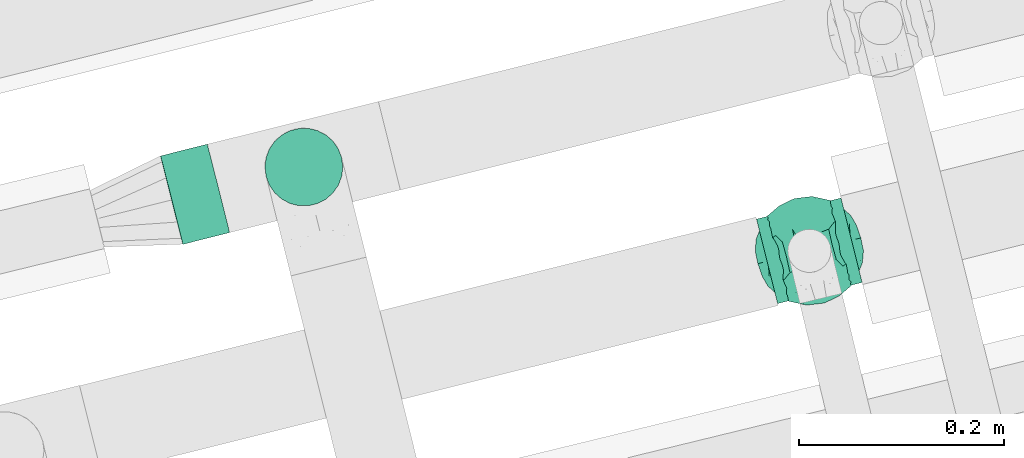
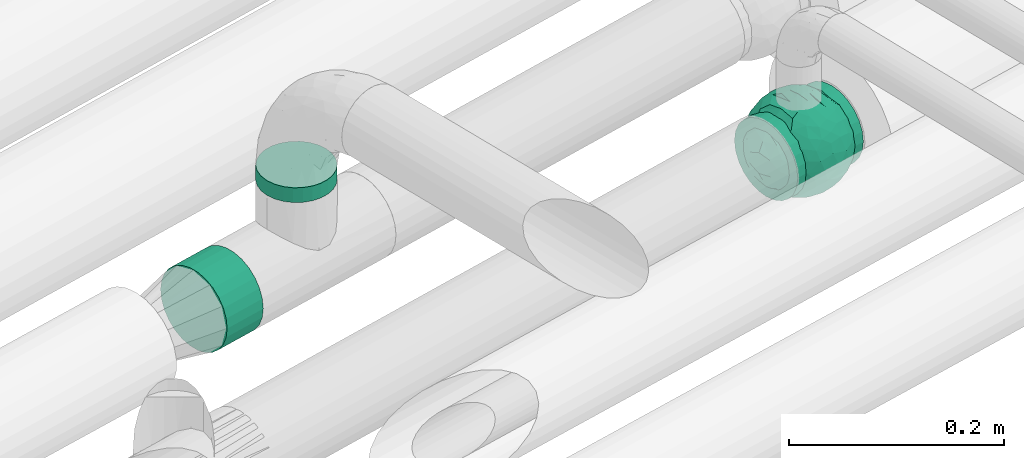
# One storey, part 53 of 93: 2 flow segments, 1 flow fitting.
"""IFC2X3 building model written with IfcOpenShell, lengths in millimetres."""

from ifc_helpers import new_model, entity, si_unit, converted_unit, derived_unit, direction, frame, origin, origin_2d_with_axis, place, context, subcontext, project, spatial, circle, extrude, faceted_brep, source, transform, mapped, material, material_list, type_object, type_shapes, element, save


model = new_model("IFC2X3")

# Units and contexts
model_context = context("Model", 3, precision=0.01, world=origin(), true_north=direction((6.12303176911189e-17, 1.0)))
body_context = subcontext(model_context, "Body", "Model", "MODEL_VIEW")
ifc_project = project(units=[si_unit("LENGTHUNIT", "METRE", prefix="MILLI"), si_unit("AREAUNIT", "SQUARE_METRE"), si_unit("VOLUMEUNIT", "CUBIC_METRE"), converted_unit("PLANEANGLEUNIT", "DEGREE", entity("IfcRatioMeasure", 0.0174532925199433), si_unit("PLANEANGLEUNIT", "RADIAN"), dimensions=[0, 0, 0, 0, 0, 0, 0]), si_unit("MASSUNIT", "GRAM", prefix="KILO"), derived_unit("MASSDENSITYUNIT", [(si_unit("MASSUNIT", "GRAM", prefix="KILO"), 1), (si_unit("LENGTHUNIT", "METRE"), -3)]), derived_unit("MOMENTOFINERTIAUNIT", [(si_unit("LENGTHUNIT", "METRE"), 4)]), si_unit("TIMEUNIT", "SECOND"), si_unit("FREQUENCYUNIT", "HERTZ"), si_unit("THERMODYNAMICTEMPERATUREUNIT", "DEGREE_CELSIUS"), derived_unit("THERMALTRANSMITTANCEUNIT", [(si_unit("MASSUNIT", "GRAM", prefix="KILO"), 1), (si_unit("THERMODYNAMICTEMPERATUREUNIT", "KELVIN"), -1), (si_unit("TIMEUNIT", "SECOND"), -3)]), derived_unit("VOLUMETRICFLOWRATEUNIT", [(si_unit("LENGTHUNIT", "METRE"), 3), (si_unit("TIMEUNIT", "SECOND"), -1)]), derived_unit("MASSFLOWRATEUNIT", [(si_unit("MASSUNIT", "GRAM", prefix="KILO"), 1), (si_unit("TIMEUNIT", "SECOND"), -1)]), derived_unit("ROTATIONALFREQUENCYUNIT", [(si_unit("TIMEUNIT", "SECOND"), -1)]), si_unit("ELECTRICCURRENTUNIT", "AMPERE"), si_unit("ELECTRICVOLTAGEUNIT", "VOLT"), si_unit("POWERUNIT", "WATT"), si_unit("FORCEUNIT", "NEWTON", prefix="KILO"), si_unit("ILLUMINANCEUNIT", "LUX"), si_unit("LUMINOUSFLUXUNIT", "LUMEN"), si_unit("LUMINOUSINTENSITYUNIT", "CANDELA"), derived_unit("USERDEFINED", [(si_unit("MASSUNIT", "GRAM", prefix="KILO"), -1), (si_unit("LENGTHUNIT", "METRE"), -2), (si_unit("TIMEUNIT", "SECOND"), 3), (si_unit("LUMINOUSFLUXUNIT", "LUMEN"), 1)]), derived_unit("LINEARVELOCITYUNIT", [(si_unit("LENGTHUNIT", "METRE"), 1), (si_unit("TIMEUNIT", "SECOND"), -1)]), si_unit("PRESSUREUNIT", "PASCAL"), derived_unit("USERDEFINED", [(si_unit("LENGTHUNIT", "METRE"), -2), (si_unit("MASSUNIT", "GRAM", prefix="KILO"), 1), (si_unit("TIMEUNIT", "SECOND"), -2)]), derived_unit("LINEARFORCEUNIT", [(si_unit("MASSUNIT", "GRAM", prefix="KILO"), 1), (si_unit("LENGTHUNIT", "METRE"), 1), (si_unit("TIMEUNIT", "SECOND"), -2), (si_unit("LENGTHUNIT", "METRE"), -1)]), derived_unit("PLANARFORCEUNIT", [(si_unit("MASSUNIT", "GRAM", prefix="KILO"), 1), (si_unit("LENGTHUNIT", "METRE"), 1), (si_unit("TIMEUNIT", "SECOND"), -2), (si_unit("LENGTHUNIT", "METRE"), -2)])], contexts=[model_context])

# Site, building, storey
site_placement = place(None, origin())
site = spatial("IfcSite", under=ifc_project, at=site_placement, CompositionType="ELEMENT")
building_placement = place(site_placement, origin())
building = spatial("IfcBuilding", under=site, at=building_placement, CompositionType="ELEMENT")
storey_placement = place(building_placement, frame((0.0, 0.0, -4200.0)))
storey = spatial("IfcBuildingStorey", under=building, at=storey_placement, CompositionType="ELEMENT", Elevation=-4200.0)

# Flow segments
pipe_segment_type = type_object("IfcPipeSegmentType", PredefinedType="NOTDEFINED")
flow_segment_1_placement = place(storey_placement, frame((-11478.48, 12538.15, 2454.21)))
element("IfcFlowSegment", 1, at=flow_segment_1_placement, inside=storey, type_object=pipe_segment_type, context=body_context, shape_type="SweptSolid", body=[
    extrude(circle(Radius=44.5, at=origin_2d_with_axis()), frame((12.47, 44.75, 46.27), z_axis=(0.969659753374157, 0.244428958204898, -0.00380093110127913), x_axis=(-0.244430723866048, 0.969666757824728, 0.0)), (0.0, 0.0, 1.0), 46.970782896697),
])
flow_segment_2_placement = place(storey_placement, frame((-11376.62, 12575.58, 2583.3)))
element("IfcFlowSegment", 2, at=flow_segment_2_placement, inside=storey, type_object=pipe_segment_type, context=body_context, shape_type="SweptSolid", body=[
    extrude(circle(Radius=38.0, at=origin_2d_with_axis()), frame((39.6, 39.6, 0.0), z_axis=(0.0, 0.0, 1.0), x_axis=(-1.0, 0.0, 0.0)), (0.0, 0.0, 1.0), 16.7010620952959),
])

# Flow fitting
ifc_material_1 = material()
ifc_material_2 = material(Name="ADSK_")
ifc_material_list = material_list([ifc_material_1, ifc_material_2])
pipe_fitting_type = type_object("IfcPipeFittingType", Name="ADSK_1", PredefinedType="NOTDEFINED", material=ifc_material_list)
shared_shape = source(origin(), body_context, "Body", "Brep", [
    faceted_brep([(-42.5, 0.0, -42.5), (-42.5, -11.0, -41.05), (-42.5, -21.25, -36.81), (-42.5, -30.05, -30.05), (-42.5, -36.81, -21.25), (-42.5, -41.05, -11.0), (-42.5, -41.78, -5.5), (-42.5, -42.5, 0.0), (-42.5, -41.78, 5.5), (-42.5, -41.05, 11.0), (-42.5, -36.81, 21.25), (-42.5, -30.05, 30.05), (-42.5, -21.25, 36.81), (-42.5, -11.0, 41.05), (-42.5, 0.0, 42.5), (-42.5, 11.0, 41.05), (-42.5, 21.25, 36.81), (-42.5, 30.05, 30.05), (-42.5, 36.81, 21.25), (-42.5, 41.05, 11.0), (-42.5, 42.5, 0.0), (-42.5, 41.05, -11.0), (-42.5, 36.81, -21.25), (-42.5, 30.05, -30.05), (-42.5, 21.25, -36.81), (-42.5, 11.0, -41.05), (42.5, 11.0, -41.05), (42.5, 21.25, -36.81), (42.5, 30.05, -30.05), (42.5, 36.81, -21.25), (42.5, 41.05, -11.0), (42.5, 42.5, 0.0), (42.5, 41.05, 11.0), (42.5, 36.81, 21.25), (42.5, 30.05, 30.05), (42.5, 21.25, 36.81), (42.5, 11.0, 41.05), (42.5, 0.0, 42.5), (42.5, -11.0, 41.05), (42.5, -21.25, 36.81), (42.5, -30.05, 30.05), (42.5, -36.81, 21.25), (42.5, -41.05, 11.0), (42.5, -41.78, 5.5), (42.5, -42.5, 0.0), (42.5, -41.78, -5.5), (42.5, -41.05, -11.0), (42.5, -36.81, -21.25), (42.5, -30.05, -30.05), (42.5, -21.25, -36.81), (42.5, -11.0, -41.05), (42.5, 0.0, -42.5), (17.36, -42.02, 6.38), (18.5, -42.5, 0.0), (-18.5, -42.5, 0.0), (14.15, -40.8, 11.92), (3.25, -38.4, 18.21), (9.29, -39.37, 16.0), (6.27, -38.89, 17.11), (-17.36, -42.02, 6.38), (-17.93, -42.26, 3.19), (-14.16, -40.8, 11.91), (-9.29, -39.37, 16.0), (-6.27, -38.89, 17.1), (-3.25, -38.4, 18.21), (0.0, -38.4, 18.21), (17.93, -42.26, 3.19), (17.36, -42.02, -6.38), (3.25, -38.4, -18.21), (-17.36, -42.02, -6.38), (-17.93, -42.26, -3.19), (9.29, -39.37, -16.0), (6.27, -38.89, -17.11), (14.15, -40.8, -11.92), (17.93, -42.26, -3.19), (-3.25, -38.4, -18.21), (-6.27, -38.89, -17.1), (-9.29, -39.37, -16.0), (0.0, -38.4, -18.21), (-14.16, -40.8, -11.91), (17.87, -47.5, -4.79), (18.5, -47.5, 0.0), (17.87, -47.5, 4.79), (16.02, -47.5, 9.25), (13.08, -47.5, 13.08), (9.25, -47.5, 16.02), (4.79, -47.5, 17.87), (0.0, -47.5, 18.5), (-4.79, -47.5, 17.87), (-9.25, -47.5, 16.02), (-13.08, -47.5, 13.08), (-16.02, -47.5, 9.25), (-17.87, -47.5, 4.79), (-18.5, -47.5, 0.0), (-17.87, -47.5, -4.79), (-16.02, -47.5, -9.25), (-13.08, -47.5, -13.08), (-9.25, -47.5, -16.02), (-4.79, -47.5, -17.87), (0.0, -47.5, -18.5), (4.79, -47.5, -17.87), (9.25, -47.5, -16.02), (13.08, -47.5, -13.08), (16.02, -47.5, -9.25)], [[[0, 1, 2, 3, 4, 5, 6, 7, 8, 9, 10, 11, 12, 13, 14, 15, 16, 17, 18, 19, 20, 21, 22, 23, 24, 25]], [[26, 27, 28, 29, 30, 31, 32, 33, 34, 35, 36, 37, 38, 39, 40, 41, 42, 43, 44, 45, 46, 47, 48, 49, 50, 51]], [[43, 42, 52]], [[53, 44, 43]], [[7, 54, 8]], [[42, 55, 52]], [[41, 40, 56]], [[55, 42, 57]], [[41, 56, 58, 57]], [[40, 11, 56]], [[57, 42, 41]], [[59, 9, 8]], [[8, 54, 60, 59]], [[59, 61, 9]], [[10, 62, 63, 64]], [[10, 9, 62]], [[10, 64, 11]], [[62, 9, 61]], [[11, 64, 65, 56]], [[43, 52, 66, 53]], [[40, 39, 12, 11]], [[14, 13, 38, 37]], [[13, 12, 39, 38]], [[15, 14, 37, 36]], [[33, 32, 19, 18]], [[17, 16, 35, 34]], [[18, 17, 34, 33]], [[36, 35, 16, 15]], [[20, 19, 32, 31]], [[20, 31, 30, 21]], [[29, 28, 23, 22]], [[21, 30, 29, 22]], [[51, 50, 1, 0]], [[25, 24, 27, 26]], [[51, 0, 25, 26]], [[28, 27, 24, 23]], [[2, 1, 50, 49]], [[67, 46, 45]], [[49, 48, 3, 2]], [[48, 47, 68]], [[6, 69, 70, 54]], [[47, 71, 72, 68]], [[47, 46, 71]], [[48, 68, 3]], [[44, 53, 45]], [[6, 54, 7]], [[67, 73, 46]], [[45, 53, 74, 67]], [[46, 73, 71]], [[4, 75, 76, 77]], [[4, 3, 75]], [[77, 5, 4]], [[3, 68, 78, 75]], [[79, 69, 5]], [[69, 6, 5]], [[79, 5, 77]], [[80, 81, 82, 83, 84, 85, 86, 87, 88, 89, 90, 91, 92, 93, 94, 95, 96, 97, 98, 99, 100, 101, 102, 103]], [[92, 60, 93]], [[61, 91, 90]], [[92, 91, 59]], [[90, 89, 62]], [[92, 59, 60]], [[60, 54, 93]], [[59, 91, 61]], [[66, 52, 82]], [[88, 64, 63]], [[62, 61, 90]], [[87, 56, 65, 64]], [[85, 58, 86]], [[87, 64, 88]], [[56, 87, 86]], [[58, 85, 57]], [[55, 84, 83]], [[85, 84, 57]], [[52, 83, 82]], [[84, 55, 57]], [[56, 86, 58]], [[63, 62, 89]], [[81, 66, 82]], [[52, 55, 83]], [[66, 81, 53]], [[63, 89, 88]], [[80, 74, 81]], [[73, 103, 102]], [[80, 103, 67]], [[102, 101, 71]], [[80, 67, 74]], [[74, 53, 81]], [[67, 103, 73]], [[70, 69, 94]], [[100, 68, 72]], [[71, 73, 102]], [[99, 75, 78, 68]], [[97, 76, 98]], [[99, 68, 100]], [[75, 99, 98]], [[76, 97, 77]], [[79, 96, 95]], [[97, 96, 77]], [[69, 95, 94]], [[96, 79, 77]], [[75, 98, 76]], [[72, 71, 101]], [[93, 70, 94]], [[69, 79, 95]], [[70, 93, 54]], [[72, 101, 100]]]),
    faceted_brep([(46.38, -14.47, -21.49), (47.57, 0.0, -23.65), (51.28, -5.95, -12.54), (17.7, 5.66, -49.77), (12.28, -8.85, -50.92), (2.15, 2.87, -53.0), (-8.3, -38.19, -35.98), (-18.28, -40.66, -28.89), (-11.82, -29.03, -42.89), (40.06, -7.7, -34.03), (11.3, 28.17, -43.6), (20.41, 21.08, -44.28), (11.07, 18.92, -48.39), (51.79, 0.0, 0.0), (51.07, 6.92, -12.89), (-39.8, 12.92, -32.73), (-33.3, 12.91, -39.33), (-40.47, 3.74, -34.21), (51.79, 11.82, 0.0), (10.27, 45.23, -25.91), (18.57, 40.35, -29.15), (8.87, 37.57, -36.49), (39.0, 21.71, -28.82), (29.98, 13.37, -41.77), (30.17, 25.51, -35.52), (39.42, 8.24, -34.65), (32.29, 40.49, 0.0), (36.91, 36.81, 0.0), (35.0, 34.14, -20.79), (27.67, 44.18, 0.0), (-47.57, 0.0, -23.65), (-38.16, -9.26, -35.78), (-45.37, -12.95, -24.42), (5.76, -51.81, 0.0), (0.0, -51.83, -11.64), (8.06, -50.4, -14.75), (36.12, -33.63, -19.67), (42.51, -27.89, -15.42), (32.29, -40.49, 0.0), (-50.53, -9.19, -13.6), (46.66, -22.47, 0.0), (-50.52, 9.22, -13.61), (-46.66, 22.47, 0.0), (-44.16, 25.02, -15.71), (-39.0, 21.71, -28.82), (-45.35, 12.92, -24.47), (-0.05, -47.47, -23.85), (46.06, 13.95, -22.51), (-10.28, -45.49, -25.44), (3.12, -40.7, -34.0), (11.24, -34.38, -38.91), (18.57, -40.35, -29.15), (31.25, -15.19, -40.19), (31.09, 0.0, -43.08), (-36.91, 36.81, 0.0), (-37.82, 32.8, -17.79), (17.29, 49.18, 0.0), (16.36, 48.2, -15.2), (11.53, 50.49, 0.0), (-23.47, 44.9, -15.98), (-17.29, 49.18, 0.0), (-16.36, 48.2, -15.2), (-37.8, -32.81, -17.81), (-36.91, -36.81, 0.0), (-44.14, -25.04, -15.71), (-22.53, -31.78, -36.12), (-23.47, -44.9, -15.98), (-30.38, -38.01, -21.33), (29.72, -28.61, -33.48), (28.22, -39.05, -22.38), (-4.99, -13.62, -51.1), (-3.95, -23.43, -47.52), (0.0, -31.72, -42.62), (-9.33, 24.94, -45.97), (-11.38, 12.91, -50.26), (-20.38, 21.05, -44.31), (20.41, -21.08, -44.28), (10.92, -45.96, -24.31), (-17.29, -49.18, 0.0), (-16.38, -48.27, -14.96), (-11.53, -50.49, 0.0), (-23.05, -47.86, 0.0), (-27.67, -44.18, 0.0), (-32.29, -40.49, 0.0), (-28.59, -12.44, -43.01), (-30.36, -23.94, -36.43), (-15.25, 0.59, -50.89), (21.67, 31.55, -36.84), (27.5, 37.78, -25.27), (-2.02, 40.69, -34.1), (-0.05, 47.47, -23.85), (-10.14, 45.33, -25.77), (-10.75, 35.1, -38.4), (-18.28, 40.66, -28.89), (-30.38, 38.01, -21.33), (-32.29, 40.49, 0.0), (-27.67, 44.18, 0.0), (-23.05, 47.86, 0.0), (0.98, 18.06, -49.95), (0.0, 31.72, -42.62), (-30.21, 25.12, -35.76), (23.46, -45.39, -14.56), (0.0, -53.13, 0.0), (-8.48, 50.24, -15.03), (-11.53, 50.49, 0.0), (-5.76, 51.81, 0.0), (-41.53, -33.12, 0.0), (-39.0, -21.71, -28.82), (-21.3, 31.75, -36.88), (51.79, -11.82, 0.0), (39.0, -21.71, -28.82), (41.53, -33.12, 0.0), (46.66, 22.47, 0.0), (43.6, 26.01, -15.64), (22.77, -10.48, -46.84), (21.09, -32.2, -36.62), (27.67, -44.18, 0.0), (8.79, -24.03, -46.56), (-20.38, -21.05, -44.31), (-18.66, -10.27, -48.67), (-31.09, 0.0, -43.08), (-23.67, 8.98, -46.71), (23.05, -47.86, 0.0), (-8.24, -50.28, -15.03), (23.47, 45.01, -15.67), (23.05, 47.86, 0.0), (8.44, 50.21, -15.18), (5.76, 51.81, 0.0), (-46.66, -22.47, 0.0), (-41.53, 33.12, 0.0), (-51.79, 11.82, 0.0), (-51.79, -11.82, 0.0), (-51.79, 0.0, 0.0), (0.0, 53.12, 0.0), (0.0, 51.81, -11.73), (-5.76, -51.81, 0.0), (17.29, -49.18, 0.0), (11.53, -50.49, 0.0), (41.53, 33.12, 0.0), (36.91, -36.81, 0.0), (-46.38, -14.47, 21.49), (-47.57, 0.0, 23.65), (-51.28, -5.95, 12.54), (-17.7, 5.66, 49.77), (-12.28, -8.85, 50.92), (-2.15, 2.87, 53.0), (8.3, -38.19, 35.98), (18.28, -40.66, 28.89), (11.82, -29.03, 42.89), (-40.06, -7.7, 34.03), (-11.3, 28.17, 43.6), (-20.41, 21.08, 44.28), (-11.07, 18.92, 48.39), (-51.07, 6.92, 12.89), (39.8, 12.92, 32.73), (33.3, 12.91, 39.33), (40.47, 3.74, 34.21), (-10.27, 45.23, 25.91), (-18.57, 40.35, 29.15), (-8.87, 37.57, 36.49), (-39.0, 21.71, 28.82), (-29.98, 13.37, 41.77), (-30.17, 25.51, 35.52), (-39.42, 8.24, 34.65), (-35.0, 34.14, 20.79), (47.57, 0.0, 23.65), (38.16, -9.26, 35.78), (45.37, -12.95, 24.42), (0.0, -51.83, 11.64), (-8.06, -50.4, 14.75), (-36.12, -33.63, 19.67), (-42.51, -27.89, 15.42), (50.53, -9.19, 13.6), (50.52, 9.22, 13.61), (44.16, 25.02, 15.71), (39.0, 21.71, 28.82), (45.35, 12.92, 24.47), (0.05, -47.47, 23.85), (-46.06, 13.95, 22.51), (10.28, -45.49, 25.44), (-3.12, -40.7, 34.0), (-11.24, -34.38, 38.91), (-18.57, -40.35, 29.15), (-31.25, -15.19, 40.19), (-31.09, 0.0, 43.08), (37.82, 32.8, 17.79), (-16.36, 48.2, 15.2), (23.47, 44.9, 15.98), (16.36, 48.2, 15.2), (37.8, -32.81, 17.81), (44.14, -25.04, 15.71), (22.53, -31.78, 36.12), (23.47, -44.9, 15.98), (30.38, -38.01, 21.33), (-29.72, -28.61, 33.48), (-28.22, -39.05, 22.38), (4.99, -13.62, 51.1), (3.95, -23.43, 47.52), (0.0, -31.72, 42.62), (9.33, 24.94, 45.97), (11.38, 12.91, 50.26), (20.38, 21.05, 44.31), (-20.41, -21.08, 44.28), (-10.92, -45.96, 24.31), (16.38, -48.27, 14.96), (28.59, -12.44, 43.01), (30.36, -23.94, 36.43), (15.25, 0.59, 50.89), (-21.67, 31.55, 36.84), (-27.5, 37.78, 25.27), (2.02, 40.69, 34.1), (0.05, 47.47, 23.85), (10.14, 45.33, 25.77), (10.75, 35.1, 38.4), (18.28, 40.66, 28.89), (30.38, 38.01, 21.33), (-0.98, 18.06, 49.95), (0.0, 31.72, 42.62), (30.21, 25.12, 35.76), (-23.46, -45.39, 14.56), (8.48, 50.24, 15.03), (39.0, -21.71, 28.82), (21.3, 31.75, 36.88), (-39.0, -21.71, 28.82), (-43.6, 26.01, 15.64), (-22.77, -10.48, 46.84), (-21.09, -32.2, 36.62), (-8.79, -24.03, 46.56), (20.38, -21.05, 44.31), (18.66, -10.27, 48.67), (31.09, 0.0, 43.08), (23.67, 8.98, 46.71), (8.24, -50.28, 15.03), (-23.47, 45.01, 15.67), (-8.44, 50.21, 15.18), (0.0, 51.81, 11.73)], [[[0, 1, 2]], [[3, 4, 5]], [[6, 7, 8]], [[1, 0, 9]], [[10, 11, 12]], [[13, 2, 14]], [[15, 16, 17]], [[14, 18, 13]], [[19, 20, 21]], [[22, 23, 24]], [[1, 9, 25]], [[26, 27, 28, 29]], [[30, 31, 32]], [[33, 34, 35]], [[36, 37, 38]], [[32, 39, 30]], [[2, 40, 0]], [[23, 22, 25]], [[41, 42, 43]], [[44, 15, 45]], [[46, 35, 34]], [[25, 22, 47]], [[31, 30, 17]], [[48, 49, 46]], [[50, 51, 49]], [[52, 53, 9]], [[43, 54, 55]], [[56, 57, 58]], [[59, 60, 61]], [[62, 63, 64]], [[8, 7, 65]], [[7, 66, 67]], [[68, 36, 69]], [[70, 5, 4]], [[8, 71, 72]], [[73, 74, 75]], [[68, 76, 52]], [[77, 46, 49]], [[78, 79, 80]], [[7, 6, 48]], [[67, 81, 82, 83]], [[84, 85, 31]], [[85, 65, 67]], [[70, 86, 5]], [[23, 3, 11]], [[21, 87, 10]], [[21, 20, 87]], [[28, 24, 88]], [[19, 89, 90]], [[91, 90, 89]], [[91, 92, 93]], [[94, 95, 96, 97]], [[98, 99, 10]], [[100, 16, 44]], [[77, 51, 101]], [[33, 102, 34]], [[103, 91, 61]], [[93, 59, 61]], [[104, 105, 103]], [[106, 64, 63]], [[107, 31, 85]], [[100, 94, 108]], [[108, 93, 92]], [[43, 55, 44]], [[0, 40, 37]], [[2, 13, 109]], [[2, 1, 14]], [[110, 9, 0]], [[2, 109, 40]], [[37, 40, 111]], [[47, 14, 1]], [[112, 14, 47]], [[113, 112, 47]], [[112, 18, 14]], [[47, 22, 113]], [[52, 9, 110]], [[53, 25, 9]], [[25, 47, 1]], [[23, 25, 53]], [[68, 52, 110]], [[76, 4, 114]], [[51, 115, 69]], [[50, 115, 51]], [[110, 36, 68]], [[3, 23, 53]], [[23, 11, 24]], [[52, 76, 114]], [[98, 12, 5]], [[11, 87, 24]], [[24, 28, 22]], [[87, 88, 24]], [[36, 116, 69]], [[28, 27, 113]], [[114, 3, 53]], [[76, 115, 117]], [[70, 4, 117]], [[118, 84, 119]], [[119, 70, 118]], [[120, 16, 121]], [[37, 36, 110]], [[116, 36, 38]], [[116, 122, 69]], [[34, 123, 46]], [[10, 87, 11]], [[87, 20, 88]], [[12, 98, 10]], [[10, 99, 21]], [[74, 5, 86]], [[73, 75, 108]], [[124, 56, 125]], [[124, 29, 88]], [[89, 21, 99]], [[21, 89, 19]], [[92, 89, 99]], [[89, 92, 91]], [[126, 127, 58]], [[88, 29, 28]], [[20, 57, 124]], [[88, 20, 124]], [[57, 20, 19]], [[73, 92, 99]], [[92, 73, 108]], [[99, 98, 73]], [[74, 86, 121]], [[73, 98, 74]], [[5, 74, 98]], [[100, 108, 75]], [[94, 93, 108]], [[86, 120, 121]], [[100, 44, 55]], [[75, 16, 100]], [[17, 16, 120]], [[31, 17, 120]], [[17, 30, 45]], [[84, 31, 120]], [[31, 107, 32]], [[41, 45, 30]], [[43, 44, 45]], [[107, 64, 32]], [[39, 64, 128]], [[30, 39, 41]], [[129, 43, 42]], [[41, 130, 42]], [[43, 45, 41]], [[62, 83, 63]], [[95, 94, 55]], [[100, 55, 94]], [[64, 107, 62]], [[131, 39, 128]], [[64, 106, 128]], [[85, 62, 107]], [[67, 83, 62]], [[39, 32, 64]], [[130, 41, 132]], [[59, 97, 60]], [[133, 127, 134]], [[59, 94, 97]], [[104, 61, 60]], [[94, 59, 93]], [[126, 134, 127]], [[126, 58, 57]], [[19, 90, 126]], [[134, 105, 133]], [[126, 90, 134]], [[103, 90, 91]], [[105, 134, 103]], [[90, 103, 134]], [[119, 120, 86]], [[84, 118, 85]], [[65, 85, 118]], [[62, 85, 67]], [[8, 65, 118]], [[67, 65, 7]], [[71, 118, 70]], [[8, 72, 6]], [[49, 6, 72]], [[6, 49, 48]], [[50, 49, 72]], [[77, 49, 51]], [[101, 69, 122]], [[123, 34, 135]], [[101, 122, 136]], [[137, 77, 136]], [[78, 81, 66]], [[7, 79, 66]], [[67, 66, 81]], [[79, 7, 48]], [[35, 137, 33]], [[123, 80, 79]], [[135, 34, 102]], [[35, 46, 77]], [[80, 123, 135]], [[46, 123, 48]], [[117, 50, 72]], [[115, 76, 68]], [[117, 72, 71]], [[4, 76, 117]], [[39, 132, 41]], [[39, 131, 132]], [[137, 35, 77]], [[124, 57, 56]], [[126, 57, 19]], [[103, 61, 104]], [[61, 91, 93]], [[77, 101, 136]], [[51, 69, 101]], [[28, 113, 22]], [[112, 113, 138]], [[16, 75, 121]], [[74, 121, 75]], [[66, 79, 78]], [[123, 79, 48]], [[0, 37, 110]], [[37, 111, 139, 38]], [[29, 124, 125]], [[115, 50, 117]], [[69, 115, 68]], [[120, 119, 84]], [[70, 119, 86]], [[11, 3, 12]], [[5, 12, 3]], [[118, 71, 8]], [[117, 71, 70]], [[3, 114, 4]], [[53, 52, 114]], [[27, 138, 113]], [[45, 15, 17]], [[44, 16, 15]], [[55, 54, 95]], [[43, 129, 54]], [[140, 141, 142]], [[143, 144, 145]], [[146, 147, 148]], [[141, 140, 149]], [[150, 151, 152]], [[132, 142, 153]], [[154, 155, 156]], [[153, 130, 132]], [[157, 158, 159]], [[160, 161, 162]], [[141, 149, 163]], [[95, 54, 164, 96]], [[165, 166, 167]], [[135, 168, 169]], [[170, 171, 83]], [[167, 172, 165]], [[142, 128, 140]], [[161, 160, 163]], [[173, 112, 174]], [[175, 154, 176]], [[177, 169, 168]], [[163, 160, 178]], [[166, 165, 156]], [[179, 180, 177]], [[181, 182, 180]], [[183, 184, 149]], [[174, 27, 185]], [[60, 186, 104]], [[187, 56, 188]], [[189, 139, 190]], [[148, 147, 191]], [[147, 192, 193]], [[194, 170, 195]], [[196, 145, 144]], [[148, 197, 198]], [[199, 200, 201]], [[194, 202, 183]], [[203, 177, 180]], [[136, 204, 137]], [[147, 146, 179]], [[193, 122, 116, 38]], [[205, 206, 166]], [[206, 191, 193]], [[196, 207, 145]], [[161, 143, 151]], [[159, 208, 150]], [[159, 158, 208]], [[164, 162, 209]], [[157, 210, 211]], [[212, 211, 210]], [[212, 213, 214]], [[215, 26, 29, 125]], [[216, 217, 150]], [[218, 155, 175]], [[203, 182, 219]], [[135, 102, 168]], [[220, 212, 188]], [[214, 187, 188]], [[58, 127, 220]], [[111, 190, 139]], [[221, 166, 206]], [[218, 215, 222]], [[222, 214, 213]], [[174, 185, 175]], [[140, 128, 171]], [[142, 132, 131]], [[142, 141, 153]], [[223, 149, 140]], [[142, 131, 128]], [[171, 128, 106]], [[178, 153, 141]], [[42, 153, 178]], [[224, 42, 178]], [[42, 130, 153]], [[178, 160, 224]], [[183, 149, 223]], [[184, 163, 149]], [[163, 178, 141]], [[161, 163, 184]], [[194, 183, 223]], [[202, 144, 225]], [[182, 226, 195]], [[181, 226, 182]], [[223, 170, 194]], [[143, 161, 184]], [[161, 151, 162]], [[183, 202, 225]], [[216, 152, 145]], [[151, 208, 162]], [[162, 164, 160]], [[208, 209, 162]], [[170, 82, 195]], [[164, 54, 224]], [[225, 143, 184]], [[202, 226, 227]], [[196, 144, 227]], [[228, 205, 229]], [[229, 196, 228]], [[230, 155, 231]], [[171, 170, 223]], [[82, 170, 83]], [[82, 81, 195]], [[168, 232, 177]], [[150, 208, 151]], [[208, 158, 209]], [[152, 216, 150]], [[150, 217, 159]], [[200, 145, 207]], [[199, 201, 222]], [[233, 60, 97]], [[233, 96, 209]], [[210, 159, 217]], [[159, 210, 157]], [[213, 210, 217]], [[210, 213, 212]], [[234, 105, 104]], [[209, 96, 164]], [[158, 186, 233]], [[209, 158, 233]], [[186, 158, 157]], [[199, 213, 217]], [[213, 199, 222]], [[217, 216, 199]], [[200, 207, 231]], [[199, 216, 200]], [[145, 200, 216]], [[218, 222, 201]], [[215, 214, 222]], [[207, 230, 231]], [[218, 175, 185]], [[201, 155, 218]], [[156, 155, 230]], [[166, 156, 230]], [[156, 165, 176]], [[205, 166, 230]], [[166, 221, 167]], [[173, 176, 165]], [[174, 175, 176]], [[221, 190, 167]], [[172, 190, 40]], [[165, 172, 173]], [[138, 174, 112]], [[173, 18, 112]], [[174, 176, 173]], [[189, 38, 139]], [[26, 215, 185]], [[218, 185, 215]], [[190, 221, 189]], [[109, 172, 40]], [[190, 111, 40]], [[206, 189, 221]], [[193, 38, 189]], [[172, 167, 190]], [[18, 173, 13]], [[187, 125, 56]], [[133, 105, 235]], [[187, 215, 125]], [[58, 188, 56]], [[215, 187, 214]], [[234, 235, 105]], [[234, 104, 186]], [[157, 211, 234]], [[235, 127, 133]], [[234, 211, 235]], [[220, 211, 212]], [[127, 235, 220]], [[211, 220, 235]], [[229, 230, 207]], [[205, 228, 206]], [[191, 206, 228]], [[189, 206, 193]], [[148, 191, 228]], [[193, 191, 147]], [[197, 228, 196]], [[148, 198, 146]], [[180, 146, 198]], [[146, 180, 179]], [[181, 180, 198]], [[203, 180, 182]], [[219, 195, 81]], [[232, 168, 33]], [[219, 81, 78]], [[80, 203, 78]], [[136, 122, 192]], [[147, 204, 192]], [[193, 192, 122]], [[204, 147, 179]], [[169, 80, 135]], [[232, 137, 204]], [[33, 168, 102]], [[169, 177, 203]], [[137, 232, 33]], [[177, 232, 179]], [[227, 181, 198]], [[226, 202, 194]], [[227, 198, 197]], [[144, 202, 227]], [[172, 13, 173]], [[172, 109, 13]], [[80, 169, 203]], [[233, 186, 60]], [[234, 186, 157]], [[220, 188, 58]], [[188, 212, 214]], [[203, 219, 78]], [[182, 195, 219]], [[164, 224, 160]], [[42, 224, 129]], [[155, 201, 231]], [[200, 231, 201]], [[192, 204, 136]], [[232, 204, 179]], [[140, 171, 223]], [[171, 106, 63, 83]], [[96, 233, 97]], [[226, 181, 227]], [[195, 226, 194]], [[230, 229, 205]], [[196, 229, 207]], [[151, 143, 152]], [[145, 152, 143]], [[228, 197, 148]], [[227, 197, 196]], [[143, 225, 144]], [[184, 183, 225]], [[54, 129, 224]], [[176, 154, 156]], [[175, 155, 154]], [[185, 27, 26]], [[174, 138, 27]]]),
])
type_shapes(pipe_fitting_type, [shared_shape])
flow_fitting_placement = place(storey_placement, frame((-10843.72, 12533.47, 2503.64), z_axis=(-0.24189419226589, 0.970302633072812, 0.0), x_axis=(0.970302633072812, 0.24189419226589, 0.0)))
element("IfcFlowFitting", 3, at=flow_fitting_placement, inside=storey, type_object=pipe_fitting_type, material=ifc_material_list, Name="ADSK_1", ObjectType="ADSK_1", context=body_context, shape_type="MappedRepresentation", body=[
    mapped(shared_shape, transform((0.0, 0.0, 0.0), scale=1.0)),
])

save(model, "model.ifc")
